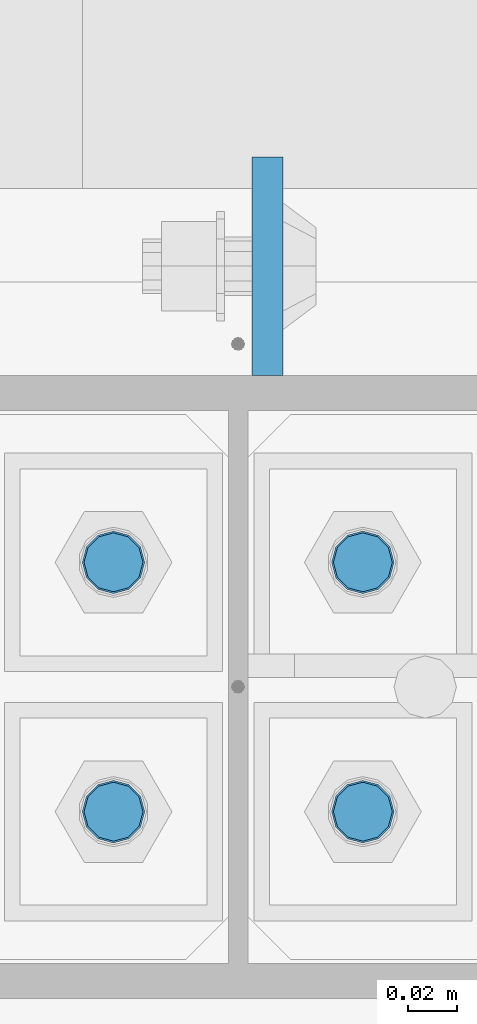
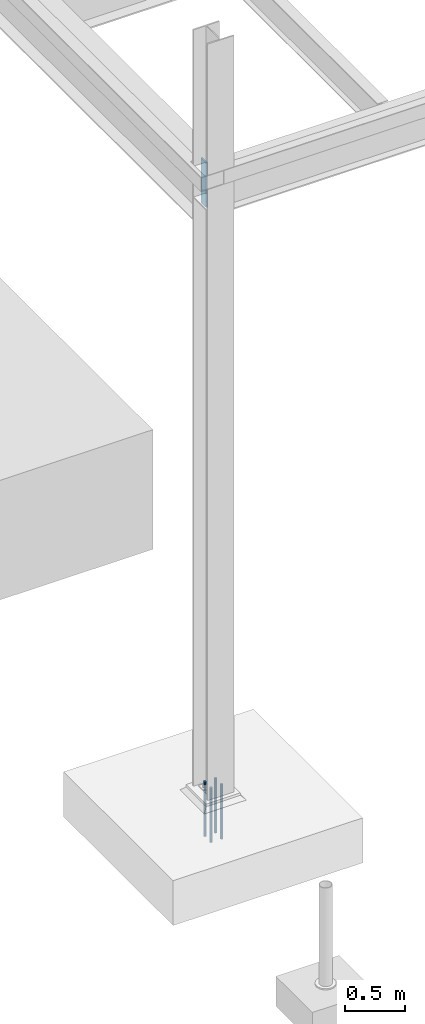
# One storey, part 1537 of 3843: 5 columns, 2 elements without a shape of their own.
"""IFC2X3 building model written with IfcOpenShell, lengths in millimetres."""

from ifc_helpers import new_model, si_unit, frame, origin_with_axes, place, context, subcontext, project, spatial, faceted_brep, material, type_object, element, aggregate, save


model = new_model("IFC2X3")

# Units and contexts
model_context = context("Model", 3, precision=1e-05, world=origin_with_axes())
body_context = subcontext(model_context, "Body", "Model", "MODEL_VIEW")
ifc_project = project(units=[si_unit("LENGTHUNIT", "METRE", prefix="MILLI"), si_unit("AREAUNIT", "SQUARE_METRE"), si_unit("VOLUMEUNIT", "CUBIC_METRE"), si_unit("MASSUNIT", "GRAM", prefix="KILO"), si_unit("TIMEUNIT", "SECOND"), si_unit("PLANEANGLEUNIT", "RADIAN"), si_unit("SOLIDANGLEUNIT", "STERADIAN"), si_unit("THERMODYNAMICTEMPERATUREUNIT", "DEGREE_CELSIUS"), si_unit("LUMINOUSINTENSITYUNIT", "LUMEN")], contexts=[model_context])

# Site, building, storey
site_placement = place(None, origin_with_axes())
site = spatial("IfcSite", under=ifc_project, at=site_placement, CompositionType="ELEMENT")
building_placement = place(site_placement, origin_with_axes())
building = spatial("IfcBuilding", under=site, at=building_placement, Name="Undefined", CompositionType="ELEMENT")
storey_placement = place(building_placement, origin_with_axes())
storey = spatial("IfcBuildingStorey", under=building, at=storey_placement, Name="Undefined", CompositionType="ELEMENT", Elevation=0.0)

# Assembly, columns
assembly_1_placement = place(storey_placement, origin_with_axes())
assembly_1 = element("IfcElementAssembly", 1, at=assembly_1_placement, inside=storey, Name="TEMPLATE", AssemblyPlace="NOTDEFINED", PredefinedType="RIGID_FRAME")
ifc_material_1 = material(Name="Undefined/F1554-GR.55")
column_type_1 = type_object("IfcColumnType", PredefinedType="NOTDEFINED")
column_1_placement = place(assembly_1_placement, frame((-50.8, 89065.1, 30022.8), z_axis=(0.0, -1.0, 0.0), x_axis=(0.0, 0.0, -1.0)))
column_1 = element("IfcColumn", 2, at=column_1_placement, type_object=column_type_1, material=ifc_material_1, Name="ANCHOR_ROD", context=body_context, shape_type="Brep", body=[
    faceted_brep([(-127.0, -10.3923048454162, 6.0), (-127.0, -6.0, 10.3923048454126), (-127.0, 0.0, 12.0), (-127.0, 6.0, 10.3923048454126), (-127.0, 10.3923048454162, 6.0), (-127.0, 12.0, 0.0), (-127.0, 10.3923048454162, -6.0), (-127.0, 6.0, -10.3923048454126), (-127.0, 0.0, -12.0), (-127.0, -6.0, -10.3923048454126), (-127.0, -10.3923048454162, -6.0), (-127.0, -12.0, 0.0), (0.0, 12.0, 0.0), (0.0, 10.3923048454162, -6.0), (0.0, 6.0, -10.3923048454126), (0.0, 0.0, -12.0), (0.0, -6.0, -10.3923048454126), (0.0, -10.3923048454162, -6.0), (0.0, -12.0, 0.0), (0.0, -10.3923048454162, 6.0), (0.0, -6.0, 10.3923048454126), (0.0, 0.0, 12.0), (0.0, 6.0, 10.3923048454126), (0.0, 10.3923048454162, 6.0), (0.0, -10.9985226280696, 6.34999999999854), (0.0, -6.35000000000582, 10.9985226280623), (0.0, 0.0, 12.6999999999971), (0.0, 6.35000000000582, 10.9985226280623), (0.0, 10.9985226280696, 6.34999999999854), (0.0, 12.6999999999971, 0.0), (0.0, 10.9985226280696, -6.34999999999854), (0.0, 6.35000000000582, -10.9985226280623), (0.0, 0.0, -12.6999999999971), (0.0, -6.35000000000582, -10.9985226280623), (0.0, -10.9985226280696, -6.34999999999854), (0.0, -12.6999999999971, 0.0), (304.799999999999, -12.6999999999971, 0.0), (304.799999999999, -10.9985226280623, 6.35000000000036), (304.799999999999, -6.34999999999854, 10.9985226280623), (304.799999999999, 0.0, 12.7000000000007), (304.799999999999, 6.34999999999854, 10.9985226280623), (304.799999999999, 10.9985226280623, 6.35000000000036), (304.799999999999, 12.6999999999971, 0.0), (304.799999999999, 10.9985226280623, -6.35000000000036), (304.799999999999, 6.34999999999854, -10.9985226280623), (304.799999999999, 0.0, -12.7000000000007), (304.799999999999, -6.34999999999854, -10.9985226280623), (304.799999999999, -10.9985226280623, -6.35000000000036), (304.799999999999, -6.0, 10.3923048454126), (304.799999999999, 0.0, 12.0), (304.799999999999, 6.0, 10.3923048454126), (304.799999999999, 10.3923048454162, 6.0), (304.799999999999, 12.0, 0.0), (304.799999999999, 10.3923048454162, -6.0), (304.799999999999, 6.0, -10.3923048454126), (304.799999999999, 0.0, -12.0), (304.799999999999, -6.0, -10.3923048454126), (304.799999999999, -10.3923048454162, -6.0), (304.799999999999, -12.0, 0.0), (304.799999999999, -10.3923048454162, 6.0), (431.799999999999, -6.0, -10.3923048454126), (431.799999999999, 0.0, -12.0), (431.799999999999, 6.0, -10.3923048454126), (431.799999999999, 10.3923048454162, -6.0), (431.799999999999, 12.0, 0.0), (431.799999999999, 10.3923048454162, 6.0), (431.799999999999, 6.0, 10.3923048454126), (431.799999999999, 0.0, 12.0), (431.799999999999, -6.0, 10.3923048454126), (431.799999999999, -10.3923048454162, 6.0), (431.799999999999, -12.0, 0.0), (431.799999999999, -10.3923048454162, -6.0)], [[[0, 1, 2, 3, 4, 5, 6, 7, 8, 9, 10, 11]], [[6, 5, 12, 13]], [[7, 6, 13, 14]], [[8, 7, 14, 15]], [[9, 8, 15, 16]], [[10, 9, 16, 17]], [[11, 10, 17, 18]], [[0, 11, 18, 19]], [[1, 0, 19, 20]], [[2, 1, 20, 21]], [[3, 2, 21, 22]], [[4, 3, 22, 23]], [[5, 4, 23, 12]], [[24, 25, 26, 27, 28, 29, 30, 31, 32, 33, 34, 35], [22, 21, 20, 19, 18, 17, 16, 15, 14, 13, 12, 23]], [[24, 35, 36, 37]], [[25, 24, 37, 38]], [[26, 25, 38, 39]], [[27, 26, 39, 40]], [[28, 27, 40, 41]], [[29, 28, 41, 42]], [[30, 29, 42, 43]], [[31, 30, 43, 44]], [[32, 31, 44, 45]], [[33, 32, 45, 46]], [[34, 33, 46, 47]], [[35, 34, 47, 36]], [[46, 45, 44, 43, 42, 41, 40, 39, 38, 37, 36, 47], [48, 49, 50, 51, 52, 53, 54, 55, 56, 57, 58, 59]], [[60, 61, 62, 63, 64, 65, 66, 67, 68, 69, 70, 71]], [[68, 67, 49, 48]], [[69, 68, 48, 59]], [[70, 69, 59, 58]], [[71, 70, 58, 57]], [[60, 71, 57, 56]], [[61, 60, 56, 55]], [[62, 61, 55, 54]], [[63, 62, 54, 53]], [[64, 63, 53, 52]], [[65, 64, 52, 51]], [[66, 65, 51, 50]], [[67, 66, 50, 49]]]),
])
column_2_placement = place(assembly_1_placement, frame((50.8, 89065.1, 30022.8), z_axis=(0.0, 1.0, 0.0), x_axis=(0.0, 0.0, -1.0)))
column_2 = element("IfcColumn", 3, at=column_2_placement, type_object=column_type_1, material=ifc_material_1, Name="ANCHOR_ROD", context=body_context, shape_type="Brep", body=[
    faceted_brep([(-127.0, -10.3923048454162, 6.0), (-127.0, -6.0, 10.3923048454126), (-127.0, 0.0, 12.0), (-127.0, 6.0, 10.3923048454126), (-127.0, 10.3923048454162, 6.0), (-127.0, 12.0, 0.0), (-127.0, 10.3923048454162, -6.0), (-127.0, 6.0, -10.3923048454126), (-127.0, 0.0, -12.0), (-127.0, -6.0, -10.3923048454126), (-127.0, -10.3923048454162, -6.0), (-127.0, -12.0, 0.0), (0.0, 12.0, 0.0), (0.0, 10.3923048454162, -6.0), (0.0, 6.0, -10.3923048454126), (0.0, 0.0, -12.0), (0.0, -6.0, -10.3923048454126), (0.0, -10.3923048454162, -6.0), (0.0, -12.0, 0.0), (0.0, -10.3923048454162, 6.0), (0.0, -6.0, 10.3923048454126), (0.0, 0.0, 12.0), (0.0, 6.0, 10.3923048454126), (0.0, 10.3923048454162, 6.0), (0.0, -10.9985226280696, 6.34999999999854), (0.0, -6.35000000000582, 10.9985226280623), (0.0, 0.0, 12.6999999999971), (0.0, 6.35000000000582, 10.9985226280623), (0.0, 10.9985226280696, 6.34999999999854), (0.0, 12.6999999999971, 0.0), (0.0, 10.9985226280696, -6.34999999999854), (0.0, 6.35000000000582, -10.9985226280623), (0.0, 0.0, -12.6999999999971), (0.0, -6.35000000000582, -10.9985226280623), (0.0, -10.9985226280696, -6.34999999999854), (0.0, -12.6999999999971, 0.0), (304.799999999999, -12.6999999999971, 0.0), (304.799999999999, -10.9985226280623, 6.35000000000036), (304.799999999999, -6.34999999999854, 10.9985226280623), (304.799999999999, 0.0, 12.7000000000007), (304.799999999999, 6.34999999999854, 10.9985226280623), (304.799999999999, 10.9985226280623, 6.35000000000036), (304.799999999999, 12.6999999999971, 0.0), (304.799999999999, 10.9985226280623, -6.35000000000036), (304.799999999999, 6.34999999999854, -10.9985226280623), (304.799999999999, 0.0, -12.7000000000007), (304.799999999999, -6.34999999999854, -10.9985226280623), (304.799999999999, -10.9985226280623, -6.35000000000036), (304.799999999999, -6.0, 10.3923048454126), (304.799999999999, 0.0, 12.0), (304.799999999999, 6.0, 10.3923048454126), (304.799999999999, 10.3923048454162, 6.0), (304.799999999999, 12.0, 0.0), (304.799999999999, 10.3923048454162, -6.0), (304.799999999999, 6.0, -10.3923048454126), (304.799999999999, 0.0, -12.0), (304.799999999999, -6.0, -10.3923048454126), (304.799999999999, -10.3923048454162, -6.0), (304.799999999999, -12.0, 0.0), (304.799999999999, -10.3923048454162, 6.0), (431.799999999999, -6.0, -10.3923048454126), (431.799999999999, 0.0, -12.0), (431.799999999999, 6.0, -10.3923048454126), (431.799999999999, 10.3923048454162, -6.0), (431.799999999999, 12.0, 0.0), (431.799999999999, 10.3923048454162, 6.0), (431.799999999999, 6.0, 10.3923048454126), (431.799999999999, 0.0, 12.0), (431.799999999999, -6.0, 10.3923048454126), (431.799999999999, -10.3923048454162, 6.0), (431.799999999999, -12.0, 0.0), (431.799999999999, -10.3923048454162, -6.0)], [[[0, 1, 2, 3, 4, 5, 6, 7, 8, 9, 10, 11]], [[6, 5, 12, 13]], [[7, 6, 13, 14]], [[8, 7, 14, 15]], [[9, 8, 15, 16]], [[10, 9, 16, 17]], [[11, 10, 17, 18]], [[0, 11, 18, 19]], [[1, 0, 19, 20]], [[2, 1, 20, 21]], [[3, 2, 21, 22]], [[4, 3, 22, 23]], [[5, 4, 23, 12]], [[24, 25, 26, 27, 28, 29, 30, 31, 32, 33, 34, 35], [22, 21, 20, 19, 18, 17, 16, 15, 14, 13, 12, 23]], [[24, 35, 36, 37]], [[25, 24, 37, 38]], [[26, 25, 38, 39]], [[27, 26, 39, 40]], [[28, 27, 40, 41]], [[29, 28, 41, 42]], [[30, 29, 42, 43]], [[31, 30, 43, 44]], [[32, 31, 44, 45]], [[33, 32, 45, 46]], [[34, 33, 46, 47]], [[35, 34, 47, 36]], [[46, 45, 44, 43, 42, 41, 40, 39, 38, 37, 36, 47], [48, 49, 50, 51, 52, 53, 54, 55, 56, 57, 58, 59]], [[60, 61, 62, 63, 64, 65, 66, 67, 68, 69, 70, 71]], [[68, 67, 49, 48]], [[69, 68, 48, 59]], [[70, 69, 59, 58]], [[71, 70, 58, 57]], [[60, 71, 57, 56]], [[61, 60, 56, 55]], [[62, 61, 55, 54]], [[63, 62, 54, 53]], [[64, 63, 53, 52]], [[65, 64, 52, 51]], [[66, 65, 51, 50]], [[67, 66, 50, 49]]]),
])
column_3_placement = place(assembly_1_placement, frame((-50.8, 89166.7, 30022.8), z_axis=(0.0, -1.0, 0.0), x_axis=(0.0, 0.0, -1.0)))
column_3 = element("IfcColumn", 4, at=column_3_placement, type_object=column_type_1, material=ifc_material_1, Name="ANCHOR_ROD", context=body_context, shape_type="Brep", body=[
    faceted_brep([(-127.0, -10.3923048454162, 6.0), (-127.0, -6.0, 10.3923048454126), (-127.0, 0.0, 12.0), (-127.0, 6.0, 10.3923048454126), (-127.0, 10.3923048454162, 6.0), (-127.0, 12.0, 0.0), (-127.0, 10.3923048454162, -6.0), (-127.0, 6.0, -10.3923048454126), (-127.0, 0.0, -12.0), (-127.0, -6.0, -10.3923048454126), (-127.0, -10.3923048454162, -6.0), (-127.0, -12.0, 0.0), (0.0, 12.0, 0.0), (0.0, 10.3923048454162, -6.0), (0.0, 6.0, -10.3923048454126), (0.0, 0.0, -12.0), (0.0, -6.0, -10.3923048454126), (0.0, -10.3923048454162, -6.0), (0.0, -12.0, 0.0), (0.0, -10.3923048454162, 6.0), (0.0, -6.0, 10.3923048454126), (0.0, 0.0, 12.0), (0.0, 6.0, 10.3923048454126), (0.0, 10.3923048454162, 6.0), (0.0, -10.9985226280696, 6.34999999999854), (0.0, -6.35000000000582, 10.9985226280623), (0.0, 0.0, 12.6999999999971), (0.0, 6.35000000000582, 10.9985226280623), (0.0, 10.9985226280696, 6.34999999999854), (0.0, 12.6999999999971, 0.0), (0.0, 10.9985226280696, -6.34999999999854), (0.0, 6.35000000000582, -10.9985226280623), (0.0, 0.0, -12.6999999999971), (0.0, -6.35000000000582, -10.9985226280623), (0.0, -10.9985226280696, -6.34999999999854), (0.0, -12.6999999999971, 0.0), (304.799999999999, -12.6999999999971, 0.0), (304.799999999999, -10.9985226280623, 6.35000000000036), (304.799999999999, -6.34999999999854, 10.9985226280623), (304.799999999999, 0.0, 12.7000000000007), (304.799999999999, 6.34999999999854, 10.9985226280623), (304.799999999999, 10.9985226280623, 6.35000000000036), (304.799999999999, 12.6999999999971, 0.0), (304.799999999999, 10.9985226280623, -6.35000000000036), (304.799999999999, 6.34999999999854, -10.9985226280623), (304.799999999999, 0.0, -12.7000000000007), (304.799999999999, -6.34999999999854, -10.9985226280623), (304.799999999999, -10.9985226280623, -6.35000000000036), (304.799999999999, -6.0, 10.3923048454126), (304.799999999999, 0.0, 12.0), (304.799999999999, 6.0, 10.3923048454126), (304.799999999999, 10.3923048454162, 6.0), (304.799999999999, 12.0, 0.0), (304.799999999999, 10.3923048454162, -6.0), (304.799999999999, 6.0, -10.3923048454126), (304.799999999999, 0.0, -12.0), (304.799999999999, -6.0, -10.3923048454126), (304.799999999999, -10.3923048454162, -6.0), (304.799999999999, -12.0, 0.0), (304.799999999999, -10.3923048454162, 6.0), (431.799999999999, -6.0, -10.3923048454126), (431.799999999999, 0.0, -12.0), (431.799999999999, 6.0, -10.3923048454126), (431.799999999999, 10.3923048454162, -6.0), (431.799999999999, 12.0, 0.0), (431.799999999999, 10.3923048454162, 6.0), (431.799999999999, 6.0, 10.3923048454126), (431.799999999999, 0.0, 12.0), (431.799999999999, -6.0, 10.3923048454126), (431.799999999999, -10.3923048454162, 6.0), (431.799999999999, -12.0, 0.0), (431.799999999999, -10.3923048454162, -6.0)], [[[0, 1, 2, 3, 4, 5, 6, 7, 8, 9, 10, 11]], [[6, 5, 12, 13]], [[7, 6, 13, 14]], [[8, 7, 14, 15]], [[9, 8, 15, 16]], [[10, 9, 16, 17]], [[11, 10, 17, 18]], [[0, 11, 18, 19]], [[1, 0, 19, 20]], [[2, 1, 20, 21]], [[3, 2, 21, 22]], [[4, 3, 22, 23]], [[5, 4, 23, 12]], [[24, 25, 26, 27, 28, 29, 30, 31, 32, 33, 34, 35], [22, 21, 20, 19, 18, 17, 16, 15, 14, 13, 12, 23]], [[24, 35, 36, 37]], [[25, 24, 37, 38]], [[26, 25, 38, 39]], [[27, 26, 39, 40]], [[28, 27, 40, 41]], [[29, 28, 41, 42]], [[30, 29, 42, 43]], [[31, 30, 43, 44]], [[32, 31, 44, 45]], [[33, 32, 45, 46]], [[34, 33, 46, 47]], [[35, 34, 47, 36]], [[46, 45, 44, 43, 42, 41, 40, 39, 38, 37, 36, 47], [48, 49, 50, 51, 52, 53, 54, 55, 56, 57, 58, 59]], [[60, 61, 62, 63, 64, 65, 66, 67, 68, 69, 70, 71]], [[68, 67, 49, 48]], [[69, 68, 48, 59]], [[70, 69, 59, 58]], [[71, 70, 58, 57]], [[60, 71, 57, 56]], [[61, 60, 56, 55]], [[62, 61, 55, 54]], [[63, 62, 54, 53]], [[64, 63, 53, 52]], [[65, 64, 52, 51]], [[66, 65, 51, 50]], [[67, 66, 50, 49]]]),
])
column_4_placement = place(assembly_1_placement, frame((50.8, 89166.7, 30022.8), z_axis=(0.0, 1.0, 0.0), x_axis=(0.0, 0.0, -1.0)))
column_4 = element("IfcColumn", 5, at=column_4_placement, type_object=column_type_1, material=ifc_material_1, Name="ANCHOR_ROD", context=body_context, shape_type="Brep", body=[
    faceted_brep([(-127.0, -10.3923048454162, 6.0), (-127.0, -6.0, 10.3923048454126), (-127.0, 0.0, 12.0), (-127.0, 6.0, 10.3923048454126), (-127.0, 10.3923048454162, 6.0), (-127.0, 12.0, 0.0), (-127.0, 10.3923048454162, -6.0), (-127.0, 6.0, -10.3923048454126), (-127.0, 0.0, -12.0), (-127.0, -6.0, -10.3923048454126), (-127.0, -10.3923048454162, -6.0), (-127.0, -12.0, 0.0), (0.0, 12.0, 0.0), (0.0, 10.3923048454162, -6.0), (0.0, 6.0, -10.3923048454126), (0.0, 0.0, -12.0), (0.0, -6.0, -10.3923048454126), (0.0, -10.3923048454162, -6.0), (0.0, -12.0, 0.0), (0.0, -10.3923048454162, 6.0), (0.0, -6.0, 10.3923048454126), (0.0, 0.0, 12.0), (0.0, 6.0, 10.3923048454126), (0.0, 10.3923048454162, 6.0), (0.0, -10.9985226280696, 6.34999999999854), (0.0, -6.35000000000582, 10.9985226280623), (0.0, 0.0, 12.6999999999971), (0.0, 6.35000000000582, 10.9985226280623), (0.0, 10.9985226280696, 6.34999999999854), (0.0, 12.6999999999971, 0.0), (0.0, 10.9985226280696, -6.34999999999854), (0.0, 6.35000000000582, -10.9985226280623), (0.0, 0.0, -12.6999999999971), (0.0, -6.35000000000582, -10.9985226280623), (0.0, -10.9985226280696, -6.34999999999854), (0.0, -12.6999999999971, 0.0), (304.799999999999, -12.6999999999971, 0.0), (304.799999999999, -10.9985226280623, 6.35000000000036), (304.799999999999, -6.34999999999854, 10.9985226280623), (304.799999999999, 0.0, 12.7000000000007), (304.799999999999, 6.34999999999854, 10.9985226280623), (304.799999999999, 10.9985226280623, 6.35000000000036), (304.799999999999, 12.6999999999971, 0.0), (304.799999999999, 10.9985226280623, -6.35000000000036), (304.799999999999, 6.34999999999854, -10.9985226280623), (304.799999999999, 0.0, -12.7000000000007), (304.799999999999, -6.34999999999854, -10.9985226280623), (304.799999999999, -10.9985226280623, -6.35000000000036), (304.799999999999, -6.0, 10.3923048454126), (304.799999999999, 0.0, 12.0), (304.799999999999, 6.0, 10.3923048454126), (304.799999999999, 10.3923048454162, 6.0), (304.799999999999, 12.0, 0.0), (304.799999999999, 10.3923048454162, -6.0), (304.799999999999, 6.0, -10.3923048454126), (304.799999999999, 0.0, -12.0), (304.799999999999, -6.0, -10.3923048454126), (304.799999999999, -10.3923048454162, -6.0), (304.799999999999, -12.0, 0.0), (304.799999999999, -10.3923048454162, 6.0), (431.799999999999, -6.0, -10.3923048454126), (431.799999999999, 0.0, -12.0), (431.799999999999, 6.0, -10.3923048454126), (431.799999999999, 10.3923048454162, -6.0), (431.799999999999, 12.0, 0.0), (431.799999999999, 10.3923048454162, 6.0), (431.799999999999, 6.0, 10.3923048454126), (431.799999999999, 0.0, 12.0), (431.799999999999, -6.0, 10.3923048454126), (431.799999999999, -10.3923048454162, 6.0), (431.799999999999, -12.0, 0.0), (431.799999999999, -10.3923048454162, -6.0)], [[[0, 1, 2, 3, 4, 5, 6, 7, 8, 9, 10, 11]], [[6, 5, 12, 13]], [[7, 6, 13, 14]], [[8, 7, 14, 15]], [[9, 8, 15, 16]], [[10, 9, 16, 17]], [[11, 10, 17, 18]], [[0, 11, 18, 19]], [[1, 0, 19, 20]], [[2, 1, 20, 21]], [[3, 2, 21, 22]], [[4, 3, 22, 23]], [[5, 4, 23, 12]], [[24, 25, 26, 27, 28, 29, 30, 31, 32, 33, 34, 35], [22, 21, 20, 19, 18, 17, 16, 15, 14, 13, 12, 23]], [[24, 35, 36, 37]], [[25, 24, 37, 38]], [[26, 25, 38, 39]], [[27, 26, 39, 40]], [[28, 27, 40, 41]], [[29, 28, 41, 42]], [[30, 29, 42, 43]], [[31, 30, 43, 44]], [[32, 31, 44, 45]], [[33, 32, 45, 46]], [[34, 33, 46, 47]], [[35, 34, 47, 36]], [[46, 45, 44, 43, 42, 41, 40, 39, 38, 37, 36, 47], [48, 49, 50, 51, 52, 53, 54, 55, 56, 57, 58, 59]], [[60, 61, 62, 63, 64, 65, 66, 67, 68, 69, 70, 71]], [[68, 67, 49, 48]], [[69, 68, 48, 59]], [[70, 69, 59, 58]], [[71, 70, 58, 57]], [[60, 71, 57, 56]], [[61, 60, 56, 55]], [[62, 61, 55, 54]], [[63, 62, 54, 53]], [[64, 63, 53, 52]], [[65, 64, 52, 51]], [[66, 65, 51, 50]], [[67, 66, 50, 49]]]),
])
aggregate(assembly_1, [column_1, column_2, column_3, column_4])

# Assembly, column
assembly_2_placement = place(storey_placement, origin_with_axes())
assembly_2 = element("IfcElementAssembly", 6, at=assembly_2_placement, inside=storey, Name="COLUMN", AssemblyPlace="NOTDEFINED", PredefinedType="RIGID_FRAME")
ifc_material_2 = material(Name="STEEL/A572-50")
column_type_2 = type_object("IfcColumnType", PredefinedType="NOTDEFINED")
column_5_placement = place(assembly_2_placement, frame((11.9060002326965, 89287.35, 35928.3), z_axis=(0.0, -1.0, 0.0), x_axis=(0.0, 0.0, 1.0)))
column_5 = element("IfcColumn", 7, at=column_5_placement, type_object=column_type_2, material=ifc_material_2, Name="PLATE", context=body_context, shape_type="Brep", body=[
    faceted_brep([(0.0, 6.34999999999854, -44.4500000000007), (0.0, 6.34999999999854, 44.4500000000007), (457.199999999997, 6.35000000000582, 44.4499999999971), (457.199999999997, 6.35000000000582, -44.4499999999971), (0.0, -6.34999999999854, 44.4500000000007), (457.199999999997, -6.35000000000582, 44.4499999999971), (0.0, -6.34999999999854, -44.4500000000007), (457.199999999997, -6.35000000000582, -44.4499999999971)], [[[0, 1, 2, 3]], [[1, 4, 5, 2]], [[4, 6, 7, 5]], [[6, 0, 3, 7]], [[5, 7, 3, 2]], [[6, 4, 1, 0]]]),
])
aggregate(assembly_2, [column_5])

save(model, "model.ifc")
